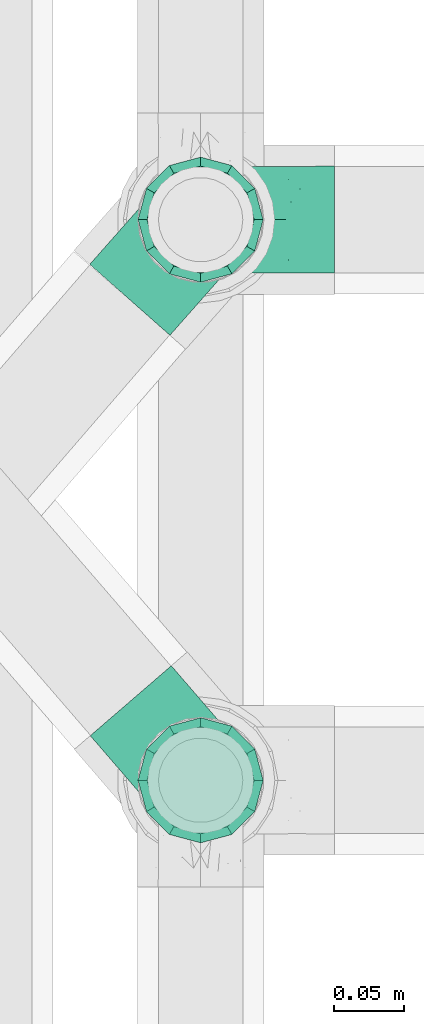
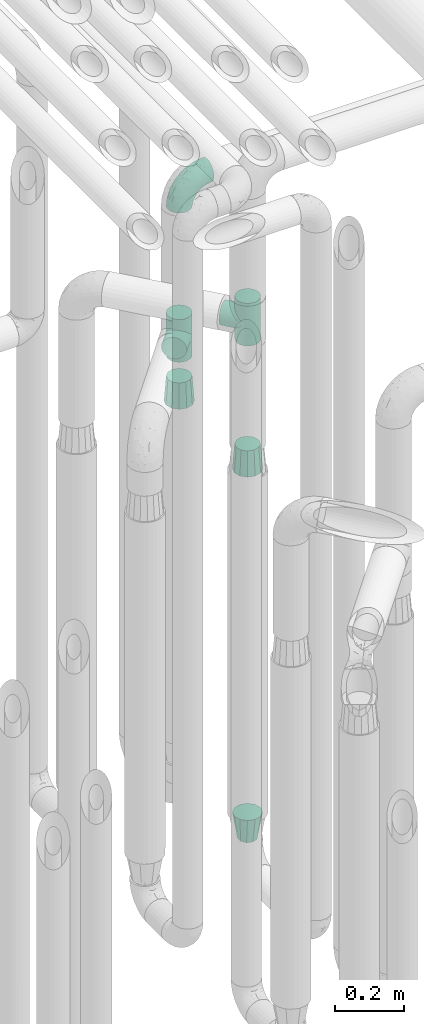
# One storey, part 626 of 827: 6 flow fittings.
"""IFC2X3 building model written with IfcOpenShell, lengths in millimetres."""

from ifc_helpers import new_model, entity, si_unit, converted_unit, derived_unit, direction, frame, origin, place, context, subcontext, project, spatial, faceted_brep, source, transform, mapped, material, type_object, type_shapes, element, save


model = new_model("IFC2X3")

# Units and contexts
model_context = context("Model", 3, precision=0.01, world=origin(), true_north=direction((6.12303176911189e-17, 1.0)))
body_context = subcontext(model_context, "Body", "Model", "MODEL_VIEW")
ifc_project = project(units=[si_unit("LENGTHUNIT", "METRE", prefix="MILLI"), si_unit("AREAUNIT", "SQUARE_METRE"), si_unit("VOLUMEUNIT", "CUBIC_METRE"), converted_unit("PLANEANGLEUNIT", "DEGREE", entity("IfcRatioMeasure", 0.0174532925199433), si_unit("PLANEANGLEUNIT", "RADIAN"), dimensions=[0, 0, 0, 0, 0, 0, 0]), si_unit("MASSUNIT", "GRAM", prefix="KILO"), derived_unit("MASSDENSITYUNIT", [(si_unit("MASSUNIT", "GRAM", prefix="KILO"), 1), (si_unit("LENGTHUNIT", "METRE"), -3)]), derived_unit("MOMENTOFINERTIAUNIT", [(si_unit("LENGTHUNIT", "METRE"), 4)]), si_unit("TIMEUNIT", "SECOND"), si_unit("FREQUENCYUNIT", "HERTZ"), si_unit("THERMODYNAMICTEMPERATUREUNIT", "DEGREE_CELSIUS"), derived_unit("THERMALTRANSMITTANCEUNIT", [(si_unit("MASSUNIT", "GRAM", prefix="KILO"), 1), (si_unit("THERMODYNAMICTEMPERATUREUNIT", "KELVIN"), -1), (si_unit("TIMEUNIT", "SECOND"), -3)]), derived_unit("VOLUMETRICFLOWRATEUNIT", [(si_unit("LENGTHUNIT", "METRE"), 3), (si_unit("TIMEUNIT", "SECOND"), -1)]), derived_unit("MASSFLOWRATEUNIT", [(si_unit("MASSUNIT", "GRAM", prefix="KILO"), 1), (si_unit("TIMEUNIT", "SECOND"), -1)]), derived_unit("ROTATIONALFREQUENCYUNIT", [(si_unit("TIMEUNIT", "SECOND"), -1)]), si_unit("ELECTRICCURRENTUNIT", "AMPERE"), si_unit("ELECTRICVOLTAGEUNIT", "VOLT"), si_unit("POWERUNIT", "WATT"), si_unit("FORCEUNIT", "NEWTON", prefix="KILO"), si_unit("ILLUMINANCEUNIT", "LUX"), si_unit("LUMINOUSFLUXUNIT", "LUMEN"), si_unit("LUMINOUSINTENSITYUNIT", "CANDELA"), derived_unit("USERDEFINED", [(si_unit("MASSUNIT", "GRAM", prefix="KILO"), -1), (si_unit("LENGTHUNIT", "METRE"), -2), (si_unit("TIMEUNIT", "SECOND"), 3), (si_unit("LUMINOUSFLUXUNIT", "LUMEN"), 1)]), derived_unit("LINEARVELOCITYUNIT", [(si_unit("LENGTHUNIT", "METRE"), 1), (si_unit("TIMEUNIT", "SECOND"), -1)]), si_unit("PRESSUREUNIT", "PASCAL"), derived_unit("USERDEFINED", [(si_unit("LENGTHUNIT", "METRE"), -2), (si_unit("MASSUNIT", "GRAM", prefix="KILO"), 1), (si_unit("TIMEUNIT", "SECOND"), -2)]), derived_unit("LINEARFORCEUNIT", [(si_unit("MASSUNIT", "GRAM", prefix="KILO"), 1), (si_unit("LENGTHUNIT", "METRE"), 1), (si_unit("TIMEUNIT", "SECOND"), -2), (si_unit("LENGTHUNIT", "METRE"), -1)]), derived_unit("PLANARFORCEUNIT", [(si_unit("MASSUNIT", "GRAM", prefix="KILO"), 1), (si_unit("LENGTHUNIT", "METRE"), 1), (si_unit("TIMEUNIT", "SECOND"), -2), (si_unit("LENGTHUNIT", "METRE"), -2)])], contexts=[model_context])

# Site, building, storey
site_placement = place(None, origin())
site = spatial("IfcSite", under=ifc_project, at=site_placement, CompositionType="ELEMENT")
building_placement = place(site_placement, origin())
building = spatial("IfcBuilding", under=site, at=building_placement, CompositionType="ELEMENT")
storey_placement = place(building_placement, frame((0.0, 0.0, 28200.0)))
storey = spatial("IfcBuildingStorey", under=building, at=storey_placement, Name="08", CompositionType="ELEMENT", Elevation=28200.0)

# Flow fittings
ifc_material = material()
pipe_fitting_type_1 = type_object("IfcPipeFittingType", Name="ADSK_1", PredefinedType="NOTDEFINED", material=ifc_material)
shared_shape_1 = source(origin(), body_context, "Body", "Brep", [
    faceted_brep([(-95.0, 19.02, -32.95), (-95.0, 9.85, -36.75), (-95.0, 0.0, -38.05), (-95.0, -9.85, -36.75), (-95.0, -19.03, -32.95), (-95.0, -26.91, -26.91), (-95.0, -32.95, -19.03), (-95.0, -36.75, -9.85), (-95.0, -38.05, 0.0), (-95.0, -36.75, 9.85), (-95.0, -32.95, 19.02), (-95.0, -26.91, 26.91), (-95.0, -19.03, 32.95), (-95.0, -9.85, 36.75), (-95.0, 0.0, 38.05), (-95.0, 9.85, 36.75), (-95.0, 19.02, 32.95), (-95.0, 26.91, 26.91), (-95.0, 32.95, 19.02), (-95.0, 36.75, 9.85), (-95.0, 38.05, 0.0), (-95.0, 36.75, -9.85), (-95.0, 32.95, -19.03), (-95.0, 26.91, -26.91), (0.0, 95.0, -38.05), (-9.85, 95.0, -36.75), (-19.02, 95.0, -32.95), (-26.91, 95.0, -26.91), (-32.95, 95.0, -19.03), (-36.75, 95.0, -9.85), (-38.05, 95.0, 0.0), (-36.75, 95.0, 9.85), (-32.95, 95.0, 19.02), (-26.91, 95.0, 26.91), (-19.02, 95.0, 32.95), (-9.85, 95.0, 36.75), (0.0, 95.0, 38.05), (9.85, 95.0, 36.75), (19.03, 95.0, 32.95), (26.91, 95.0, 26.91), (32.95, 95.0, 19.02), (36.75, 95.0, 9.85), (38.05, 95.0, 0.0), (36.75, 95.0, -9.85), (32.95, 95.0, -19.03), (26.91, 95.0, -26.91), (19.03, 95.0, -32.95), (9.85, 95.0, -36.75), (-7.99, -4.96, 6.3), (-0.92, 0.92, 0.0), (4.62, 8.1, 8.01), (-76.19, -35.57, 0.0), (-64.32, -32.32, 12.43), (20.51, 62.45, 28.68), (-60.56, -33.52, 0.0), (-70.4, -13.47, 34.42), (-39.61, -5.88, 32.32), (-49.6, 2.07, 37.1), (-70.34, -28.81, 21.71), (14.64, 40.81, 26.5), (5.88, 39.61, 32.32), (3.59, 20.77, 25.31), (-40.45, 68.06, 16.75), (-62.45, -20.51, 28.68), (-44.52, -26.87, 0.0), (-28.47, -20.22, 0.0), (-26.43, -17.83, 8.75), (-76.1, 39.63, 10.76), (-72.74, 37.58, 18.19), (-60.35, 46.18, 14.61), (-13.4, 13.4, 32.12), (-20.77, -3.59, 25.31), (-14.66, 81.47, 35.56), (-6.22, 71.26, 37.92), (-57.5, 42.48, 22.79), (-15.0, 34.74, 37.7), (-27.1, 12.08, 36.05), (-9.2, 28.81, 35.63), (-79.98, 23.7, 30.95), (-73.68, -4.3, 37.48), (-30.74, 21.67, 37.97), (-62.36, 47.59, 6.79), (-72.71, 32.83, 24.69), (-67.42, 7.02, 37.95), (-32.13, 75.27, 24.51), (-43.46, 51.47, 26.26), (-24.98, 73.15, 31.29), (20.59, 41.28, 19.85), (7.79, 16.09, 15.86), (-73.21, 42.39, 0.0), (-54.73, 54.73, 0.0), (-73.44, 15.79, 35.79), (-5.94, 4.32, 20.43), (28.81, 70.34, 21.71), (32.32, 64.32, 12.43), (-53.59, 26.2, 35.09), (-52.02, 19.31, 37.21), (21.38, 33.53, 10.34), (26.87, 44.52, 0.0), (-48.28, 12.14, 38.05), (4.3, 73.68, 37.48), (-44.08, -25.52, 12.79), (-41.28, -20.59, 19.85), (35.57, 76.19, 0.0), (-47.26, 54.3, 20.18), (-47.4, 61.99, 8.58), (-42.39, 73.21, 0.0), (-39.67, 78.86, 7.21), (-45.69, 36.84, 33.11), (-32.83, 50.13, 33.35), (13.47, 70.4, 34.42), (-18.25, 63.73, 36.07), (-40.63, -13.75, 27.22), (-16.63, 46.37, 37.95), (-53.47, 38.79, 28.59), (-26.07, 48.54, 36.15), (-34.51, 34.51, 36.86), (-2.07, 49.6, 37.1), (-22.79, -10.49, 19.23), (-61.73, 28.67, 31.87), (9.65, 14.7, 0.0), (20.22, 28.47, 0.0), (33.52, 60.56, 0.0), (-11.42, -5.44, 13.25), (-14.7, -9.65, 0.0), (-81.47, 14.66, -35.56), (-62.45, -20.51, -28.68), (-71.26, 6.22, -37.92), (-75.27, 32.13, -24.51), (-73.15, 24.98, -31.29), (13.47, 70.4, -34.42), (5.88, 39.61, -32.32), (-2.07, 49.6, -37.1), (-78.86, 39.67, -7.21), (-70.4, -13.47, -34.42), (-39.61, -5.88, -32.32), (-61.99, 47.4, -8.58), (32.32, 64.32, -12.43), (28.81, 70.34, -21.71), (-63.73, 18.25, -36.07), (-50.13, 32.83, -33.35), (4.3, 73.68, -37.48), (-7.02, 67.42, -37.95), (-39.63, 76.1, -10.76), (-46.18, 60.35, -14.61), (-47.59, 62.36, -6.79), (-64.32, -32.32, -12.43), (-26.2, 53.59, -35.09), (-15.79, 73.44, -35.79), (-19.31, 52.02, -37.21), (-37.58, 72.74, -18.19), (-70.34, -28.81, -21.71), (-42.48, 57.5, -22.79), (-38.79, 53.47, -28.59), (-51.47, 43.46, -26.26), (-32.83, 72.71, -24.69), (-46.37, 16.63, -37.95), (-73.68, -4.3, -37.48), (-41.28, -20.59, -19.85), (-44.08, -25.52, -12.79), (13.75, 40.63, -27.22), (20.51, 62.45, -28.68), (-68.06, 40.45, -16.75), (-54.3, 47.26, -20.18), (-12.14, 48.28, -38.05), (-21.67, 30.74, -37.97), (-36.84, 45.69, -33.11), (-11.42, -5.44, -13.25), (7.79, 16.09, -15.86), (4.62, 8.1, -8.01), (-23.7, 79.98, -30.95), (-26.43, -17.83, -8.75), (-7.99, -4.96, -6.3), (-40.81, -14.64, -26.5), (-20.77, -3.59, -25.31), (-34.74, 15.0, -37.7), (-12.08, 27.1, -36.05), (-28.81, 9.2, -35.63), (-22.79, -10.49, -19.23), (21.38, 33.53, -10.34), (20.59, 41.28, -19.85), (-48.54, 26.07, -36.15), (-49.6, 2.07, -37.1), (-13.4, 13.4, -32.12), (3.59, 20.77, -25.31), (-28.67, 61.73, -31.87), (-34.51, 34.51, -36.86), (-5.94, 4.32, -20.43)], [[[0, 1, 2, 3, 4, 5, 6, 7, 8, 9, 10, 11, 12, 13, 14, 15, 16, 17, 18, 19, 20, 21, 22, 23]], [[24, 25, 26, 27, 28, 29, 30, 31, 32, 33, 34, 35, 36, 37, 38, 39, 40, 41, 42, 43, 44, 45, 46, 47]], [[48, 49, 50]], [[51, 52, 9]], [[53, 39, 38]], [[9, 52, 10]], [[54, 52, 51]], [[55, 56, 57]], [[11, 10, 58]], [[59, 60, 61]], [[32, 31, 62]], [[63, 12, 11]], [[63, 55, 12]], [[64, 65, 66]], [[67, 68, 69]], [[70, 56, 71]], [[35, 72, 73]], [[69, 68, 74]], [[75, 76, 77]], [[16, 78, 17]], [[13, 79, 14]], [[76, 75, 80]], [[67, 69, 81]], [[18, 17, 82]], [[14, 79, 83]], [[20, 19, 67]], [[84, 85, 86]], [[87, 61, 88]], [[89, 81, 90]], [[18, 82, 68]], [[15, 91, 16]], [[14, 83, 15]], [[71, 92, 61]], [[17, 78, 82]], [[93, 87, 94]], [[95, 91, 96]], [[97, 98, 94]], [[86, 72, 34]], [[96, 99, 80]], [[37, 36, 100]], [[40, 39, 93]], [[40, 94, 41]], [[64, 66, 101]], [[93, 94, 40]], [[58, 102, 63]], [[94, 103, 41]], [[94, 87, 97]], [[104, 69, 74]], [[34, 33, 86]], [[105, 69, 104]], [[52, 58, 10]], [[106, 107, 30]], [[108, 109, 85]], [[105, 106, 90]], [[53, 110, 60]], [[86, 111, 72]], [[86, 109, 111]], [[33, 84, 86]], [[12, 55, 13]], [[112, 56, 63]], [[110, 38, 37]], [[34, 72, 35]], [[36, 35, 73]], [[111, 113, 73]], [[105, 107, 106]], [[110, 53, 38]], [[74, 114, 85]], [[91, 15, 83]], [[105, 90, 81]], [[107, 62, 31]], [[33, 32, 84]], [[115, 109, 116]], [[111, 115, 113]], [[100, 73, 117]], [[56, 55, 63]], [[79, 55, 57]], [[102, 118, 112]], [[56, 70, 76]], [[100, 110, 37]], [[117, 77, 60]], [[117, 60, 110]], [[60, 70, 61]], [[58, 52, 101]], [[63, 11, 58]], [[39, 53, 93]], [[87, 93, 53]], [[96, 91, 83]], [[78, 91, 119]], [[32, 62, 84]], [[84, 62, 104]], [[86, 85, 109]], [[85, 114, 108]], [[80, 113, 116]], [[117, 73, 113]], [[80, 116, 96]], [[80, 57, 76]], [[71, 112, 118]], [[61, 87, 59]], [[62, 107, 105]], [[97, 120, 121]], [[70, 71, 61]], [[71, 118, 92]], [[73, 100, 36]], [[110, 100, 117]], [[55, 79, 13]], [[83, 79, 57]], [[96, 83, 99]], [[116, 108, 95]], [[50, 97, 88]], [[97, 87, 88]], [[50, 49, 120]], [[122, 94, 98]], [[89, 20, 67]], [[105, 81, 69]], [[89, 67, 81]], [[68, 19, 18]], [[68, 67, 19]], [[74, 68, 82]], [[114, 82, 119]], [[74, 85, 104]], [[82, 114, 74]], [[114, 119, 108]], [[95, 108, 119]], [[116, 109, 108]], [[123, 48, 50]], [[97, 50, 120]], [[123, 50, 88]], [[91, 95, 119]], [[116, 95, 96]], [[84, 104, 85]], [[104, 62, 105]], [[83, 57, 99]], [[57, 80, 99]], [[66, 48, 123]], [[66, 124, 48]], [[118, 66, 123]], [[124, 66, 65]], [[66, 118, 101]], [[54, 64, 52]], [[124, 49, 48]], [[30, 107, 31]], [[91, 78, 16]], [[82, 78, 119]], [[56, 76, 57]], [[77, 76, 70]], [[60, 77, 70]], [[77, 117, 75]], [[117, 113, 75]], [[113, 80, 75]], [[9, 8, 51]], [[103, 94, 122]], [[103, 42, 41]], [[73, 72, 111]], [[113, 115, 116]], [[111, 109, 115]], [[102, 112, 63]], [[71, 56, 112]], [[118, 102, 101]], [[92, 123, 88]], [[123, 92, 118]], [[61, 92, 88]], [[87, 53, 59]], [[60, 59, 53]], [[97, 121, 98]], [[58, 101, 102]], [[64, 101, 52]], [[125, 1, 0]], [[126, 5, 4]], [[2, 1, 127]], [[1, 125, 127]], [[128, 129, 23]], [[130, 131, 132]], [[89, 133, 20]], [[126, 134, 135]], [[136, 89, 90]], [[137, 138, 44]], [[139, 129, 140]], [[24, 141, 142]], [[143, 144, 145]], [[125, 129, 139]], [[6, 146, 7]], [[147, 148, 149]], [[146, 51, 7]], [[143, 150, 144]], [[146, 6, 151]], [[152, 153, 154]], [[126, 4, 134]], [[0, 23, 129]], [[28, 155, 150]], [[43, 42, 103]], [[54, 146, 64]], [[139, 156, 127]], [[157, 3, 2]], [[151, 158, 159]], [[160, 131, 161]], [[22, 21, 162]], [[136, 144, 163]], [[149, 164, 165]], [[24, 142, 25]], [[166, 140, 154]], [[154, 129, 128]], [[143, 30, 29]], [[167, 168, 169]], [[155, 28, 27]], [[26, 170, 27]], [[171, 167, 172]], [[26, 25, 148]], [[27, 170, 155]], [[173, 135, 174]], [[144, 150, 152]], [[175, 176, 177]], [[24, 47, 141]], [[45, 161, 46]], [[148, 25, 142]], [[176, 175, 165]], [[64, 159, 171]], [[138, 45, 44]], [[130, 46, 161]], [[137, 44, 43]], [[178, 159, 158]], [[137, 103, 122]], [[163, 144, 152]], [[136, 133, 89]], [[103, 137, 43]], [[6, 5, 151]], [[178, 158, 173]], [[134, 4, 3]], [[178, 173, 174]], [[137, 98, 179]], [[145, 90, 106]], [[138, 180, 161]], [[46, 130, 47]], [[136, 90, 145]], [[133, 162, 21]], [[23, 22, 128]], [[139, 140, 181]], [[139, 181, 156]], [[157, 127, 182]], [[157, 134, 3]], [[182, 177, 135]], [[182, 135, 134]], [[135, 183, 174]], [[131, 130, 161]], [[141, 130, 132]], [[160, 180, 184]], [[131, 183, 176]], [[5, 126, 151]], [[158, 151, 126]], [[180, 138, 137]], [[161, 45, 138]], [[149, 148, 142]], [[170, 148, 185]], [[22, 162, 128]], [[128, 162, 163]], [[129, 154, 140]], [[154, 153, 166]], [[165, 156, 186]], [[182, 127, 156]], [[165, 186, 149]], [[165, 132, 176]], [[131, 184, 183]], [[187, 167, 178]], [[184, 168, 187]], [[167, 169, 172]], [[184, 180, 168]], [[174, 183, 184]], [[127, 157, 2]], [[134, 157, 182]], [[130, 141, 47]], [[142, 141, 132]], [[149, 142, 164]], [[186, 166, 147]], [[180, 179, 168]], [[169, 179, 120]], [[137, 179, 180]], [[179, 121, 120]], [[106, 30, 143]], [[136, 145, 144]], [[106, 143, 145]], [[150, 29, 28]], [[150, 143, 29]], [[152, 150, 155]], [[153, 155, 185]], [[152, 154, 163]], [[155, 153, 152]], [[153, 185, 166]], [[147, 166, 185]], [[186, 140, 166]], [[169, 120, 49]], [[169, 49, 172]], [[179, 169, 168]], [[148, 147, 185]], [[186, 147, 149]], [[128, 163, 154]], [[163, 162, 136]], [[142, 132, 164]], [[132, 165, 164]], [[171, 124, 65]], [[124, 171, 172]], [[64, 146, 159]], [[171, 159, 178]], [[171, 65, 64]], [[172, 49, 124]], [[162, 133, 136]], [[20, 133, 21]], [[148, 170, 26]], [[155, 170, 185]], [[131, 176, 132]], [[177, 176, 183]], [[135, 177, 183]], [[177, 182, 175]], [[182, 156, 175]], [[156, 165, 175]], [[51, 146, 54]], [[51, 8, 7]], [[129, 125, 0]], [[127, 125, 139]], [[140, 186, 181]], [[156, 181, 186]], [[158, 126, 173]], [[135, 173, 126]], [[187, 178, 174]], [[171, 178, 167]], [[184, 187, 174]], [[167, 187, 168]], [[180, 160, 161]], [[184, 131, 160]], [[98, 137, 122]], [[98, 121, 179]], [[151, 159, 146]]]),
])
type_shapes(pipe_fitting_type_1, [shared_shape_1])
flow_fitting_1_placement = place(storey_placement, frame((36975.03, 12979.64, 2600.0), z_axis=(0.0, 1.0, 0.0), x_axis=(0.0, 0.0, 1.0)))
element("IfcFlowFitting", 1, at=flow_fitting_1_placement, inside=storey, type_object=pipe_fitting_type_1, material=ifc_material, Name="ADSK_1", ObjectType="ADSK_1", context=body_context, shape_type="MappedRepresentation", body=[
    mapped(shared_shape_1, transform((0.0, 0.0, 0.0), scale=1.0)),
])
pipe_fitting_type_2 = type_object("IfcPipeFittingType", Name="ADSK_1", PredefinedType="NOTDEFINED", material=ifc_material)
shared_shape_2 = source(origin(), body_context, "Body", "Brep", [
    faceted_brep([(-76.0, 9.85, -36.75), (-76.0, 0.0, -38.05), (-76.0, -9.85, -36.75), (-76.0, -19.03, -32.95), (-76.0, -22.97, -29.93), (-76.0, -26.91, -26.91), (-76.0, -29.93, -22.97), (-76.0, -32.95, -19.03), (-76.0, -34.85, -14.44), (-76.0, -36.75, -9.85), (-76.0, -38.05, 0.0), (-76.0, -36.75, 9.85), (-76.0, -34.85, 14.44), (-76.0, -32.95, 19.02), (-76.0, -29.93, 22.97), (-76.0, -26.91, 26.91), (-76.0, -22.97, 29.93), (-76.0, -19.03, 32.95), (-76.0, -9.85, 36.75), (-76.0, 0.0, 38.05), (-76.0, 9.85, 36.75), (-76.0, 19.02, 32.95), (-76.0, 26.91, 26.91), (-76.0, 32.95, 19.02), (-76.0, 36.75, 9.85), (-76.0, 38.05, 0.0), (-76.0, 36.75, -9.85), (-76.0, 32.95, -19.03), (-76.0, 26.91, -26.91), (-76.0, 19.02, -32.95), (76.0, 26.91, -26.91), (76.0, 32.95, -19.03), (76.0, 36.75, -9.85), (76.0, 38.05, 0.0), (76.0, 36.75, 9.85), (76.0, 32.95, 19.02), (76.0, 26.91, 26.91), (76.0, 19.02, 32.95), (76.0, 9.85, 36.75), (76.0, 0.0, 38.05), (76.0, -9.85, 36.75), (76.0, -19.03, 32.95), (76.0, -22.97, 29.93), (76.0, -26.91, 26.91), (76.0, -29.93, 22.97), (76.0, -32.95, 19.02), (76.0, -34.85, 14.44), (76.0, -36.75, 9.85), (76.0, -38.05, 0.0), (76.0, -36.75, -9.85), (76.0, -34.85, -14.44), (76.0, -32.95, -19.03), (76.0, -29.93, -22.97), (76.0, -26.91, -26.91), (76.0, -22.97, -29.93), (76.0, -19.03, -32.95), (76.0, -9.85, -36.75), (76.0, 0.0, -38.05), (76.0, 9.85, -36.75), (76.0, 19.02, -32.95), (36.99, -36.99, 8.94), (38.05, -38.05, 0.0), (-36.99, -36.99, 8.94), (-38.05, -38.05, 0.0), (35.51, -35.51, 12.97), (34.04, -34.04, 17.0), (18.81, -18.81, 33.08), (29.74, -29.74, 23.73), (24.56, -24.56, 29.06), (-35.51, -35.51, 12.97), (-34.04, -34.04, 17.0), (-18.81, -18.81, 33.08), (-29.74, -29.74, 23.73), (-24.56, -24.56, 29.06), (-12.7, -12.7, 35.87), (6.4, -6.4, 37.51), (12.7, -12.7, 35.87), (0.0, 0.0, 38.05), (-6.4, -6.4, 37.51), (6.4, -6.4, -37.51), (0.0, 0.0, -38.05), (12.7, -12.7, -35.87), (-24.56, -24.56, -29.06), (-6.4, -6.4, -37.51), (-35.51, -35.51, -12.97), (-36.99, -36.99, -8.94), (-29.74, -29.74, -23.73), (-12.7, -12.7, -35.87), (18.81, -18.81, -33.08), (24.56, -24.56, -29.06), (-34.04, -34.04, -17.0), (29.74, -29.74, -23.73), (36.99, -36.99, -8.94), (35.51, -35.51, -12.97), (34.04, -34.04, -17.0), (-18.81, -18.81, -33.08), (9.85, -76.0, -36.75), (19.03, -76.0, -32.95), (26.91, -76.0, -26.91), (32.95, -76.0, -19.03), (36.75, -76.0, -9.85), (38.05, -76.0, 0.0), (36.75, -76.0, 9.85), (32.95, -76.0, 19.02), (26.91, -76.0, 26.91), (19.03, -76.0, 32.95), (9.85, -76.0, 36.75), (0.0, -76.0, 38.05), (-9.85, -76.0, 36.75), (-19.02, -76.0, 32.95), (-26.91, -76.0, 26.91), (-32.95, -76.0, 19.02), (-36.75, -76.0, 9.85), (-38.05, -76.0, 0.0), (-36.75, -76.0, -9.85), (-32.95, -76.0, -19.03), (-26.91, -76.0, -26.91), (-19.02, -76.0, -32.95), (-9.85, -76.0, -36.75), (0.0, -76.0, -38.05)], [[[0, 1, 2, 3, 4, 5, 6, 7, 8, 9, 10, 11, 12, 13, 14, 15, 16, 17, 18, 19, 20, 21, 22, 23, 24, 25, 26, 27, 28, 29]], [[30, 31, 32, 33, 34, 35, 36, 37, 38, 39, 40, 41, 42, 43, 44, 45, 46, 47, 48, 49, 50, 51, 52, 53, 54, 55, 56, 57, 58, 59]], [[48, 47, 60]], [[60, 61, 48]], [[62, 10, 63]], [[47, 46, 64]], [[46, 45, 65]], [[41, 66, 42]], [[43, 67, 45, 44]], [[67, 43, 68]], [[45, 67, 65]], [[68, 43, 42]], [[11, 69, 12]], [[70, 12, 69]], [[10, 62, 11]], [[11, 62, 69]], [[71, 17, 16]], [[72, 73, 15]], [[72, 15, 14, 13]], [[15, 73, 16]], [[71, 74, 17]], [[72, 13, 70]], [[46, 65, 64]], [[42, 66, 68]], [[40, 39, 75]], [[47, 64, 60]], [[66, 41, 76]], [[75, 76, 40]], [[75, 39, 77]], [[78, 77, 19]], [[76, 41, 40]], [[23, 22, 36, 35]], [[24, 23, 35, 34]], [[21, 20, 38, 37]], [[22, 21, 37, 36]], [[38, 20, 19, 77, 39]], [[25, 24, 34, 33]], [[70, 13, 12]], [[78, 18, 74]], [[18, 78, 19]], [[18, 17, 74]], [[71, 16, 73]], [[28, 27, 31, 30]], [[26, 32, 31, 27]], [[25, 33, 32, 26]], [[29, 28, 30, 59]], [[57, 56, 79]], [[58, 57, 80, 1, 0]], [[79, 56, 81]], [[82, 5, 4]], [[59, 58, 0, 29]], [[56, 55, 81]], [[57, 79, 80]], [[80, 83, 1]], [[9, 84, 85]], [[86, 7, 6, 5]], [[83, 87, 2]], [[1, 83, 2]], [[87, 3, 2]], [[88, 54, 89]], [[54, 53, 89]], [[8, 90, 84]], [[88, 55, 54]], [[91, 89, 53]], [[52, 51, 91, 53]], [[55, 88, 81]], [[49, 92, 93]], [[92, 49, 48]], [[94, 50, 93]], [[61, 92, 48]], [[85, 63, 10]], [[51, 94, 91]], [[82, 4, 95]], [[49, 93, 50]], [[4, 3, 95]], [[5, 82, 86]], [[94, 51, 50]], [[95, 3, 87]], [[9, 8, 84]], [[90, 8, 7]], [[9, 85, 10]], [[90, 7, 86]], [[96, 97, 98, 99, 100, 101, 102, 103, 104, 105, 106, 107, 108, 109, 110, 111, 112, 113, 114, 115, 116, 117, 118, 119]], [[62, 63, 113]], [[112, 62, 113]], [[110, 109, 73]], [[72, 111, 110]], [[70, 112, 111]], [[74, 109, 108]], [[112, 70, 69, 62]], [[73, 72, 110]], [[70, 111, 72]], [[74, 71, 109]], [[107, 77, 78]], [[74, 108, 78]], [[73, 109, 71]], [[78, 108, 107]], [[75, 107, 106]], [[105, 76, 106]], [[103, 102, 65]], [[67, 104, 103]], [[68, 105, 104]], [[60, 102, 101]], [[68, 66, 105]], [[76, 75, 106]], [[66, 76, 105]], [[61, 60, 101]], [[65, 67, 103]], [[102, 60, 64, 65]], [[68, 104, 67]], [[107, 75, 77]], [[61, 101, 92]], [[100, 92, 101]], [[98, 97, 89]], [[94, 100, 99]], [[98, 91, 99]], [[81, 97, 96]], [[100, 94, 93, 92]], [[89, 91, 98]], [[94, 99, 91]], [[81, 88, 97]], [[119, 80, 79]], [[81, 96, 79]], [[89, 97, 88]], [[79, 96, 119]], [[83, 119, 118]], [[117, 87, 118]], [[115, 114, 90]], [[86, 116, 115]], [[82, 117, 116]], [[85, 114, 113]], [[82, 95, 117]], [[87, 83, 118]], [[95, 87, 117]], [[63, 85, 113]], [[90, 86, 115]], [[114, 85, 84, 90]], [[82, 116, 86]], [[119, 83, 80]]]),
])
type_shapes(pipe_fitting_type_2, [shared_shape_2])
for number, where, z_axis, x_axis, name in (
    (2, (36975.03, 12580.2, 2350.0), (0.757098240256198, 0.653301044389926, 0.0), (0.0, 0.0, 1.0), "ADSK_1"),
    (3, (36975.03, 12979.64, 2050.0), (-0.749374472575658, 0.662146433843719, 0.0), (0.0, 0.0, 1.0), "ADSK_1"),
):
    element("IfcFlowFitting", number, at=place(storey_placement, frame(where, z_axis=z_axis, x_axis=x_axis)), inside=storey, type_object=pipe_fitting_type_2, material=ifc_material, Name=name, ObjectType="ADSK_1", context=body_context, shape_type="MappedRepresentation", body=[
        mapped(shared_shape_2, transform((0.0, 0.0, 0.0), scale=1.0)),
    ])
pipe_fitting_type_3 = type_object("IfcPipeFittingType", Name="ADSK_1", PredefinedType="NOTDEFINED", material=ifc_material)
shared_shape_3 = source(origin(), body_context, "Body", "Brep", [
    faceted_brep([(89.0, -44.45, 0.0), (89.0, -41.96, -9.31), (89.0, -38.49, -22.22), (89.0, -30.36, -30.36), (89.0, -22.23, -38.49), (89.0, -11.11, -41.47), (89.0, 0.0, -44.45), (89.0, 11.11, -41.47), (89.0, 22.22, -38.49), (89.0, 30.36, -30.36), (89.0, 38.49, -22.22), (89.0, 41.96, -9.31), (89.0, 44.45, 0.0), (89.0, 41.96, 9.31), (89.0, 38.49, 22.23), (89.0, 30.36, 30.36), (89.0, 22.22, 38.49), (89.0, 11.11, 41.47), (89.0, 0.0, 44.45), (89.0, -11.11, 41.47), (89.0, -22.23, 38.49), (89.0, -30.36, 30.36), (89.0, -38.49, 22.23), (89.0, -41.96, 9.31), (0.0, 38.05, 0.0), (0.0, 35.5, -9.51), (0.0, 32.95, -19.02), (0.0, 25.99, -25.99), (0.0, 19.02, -32.95), (0.0, 9.51, -35.5), (0.0, 0.0, -38.05), (0.0, -9.51, -35.5), (0.0, -19.03, -32.95), (0.0, -25.99, -25.99), (0.0, -32.95, -19.02), (0.0, -35.5, -9.51), (0.0, -38.05, 0.0), (0.0, -35.5, 9.51), (0.0, -32.95, 19.03), (0.0, -25.99, 25.99), (0.0, -19.03, 32.95), (0.0, -9.51, 35.5), (0.0, 0.0, 38.05), (0.0, 9.51, 35.5), (0.0, 19.03, 32.95), (0.0, 25.99, 25.99), (0.0, 32.95, 19.03), (0.0, 35.5, 9.51)], [[[0, 1, 2, 3, 4, 5, 6, 7, 8, 9, 10, 11, 12, 13, 14, 15, 16, 17, 18, 19, 20, 21, 22, 23]], [[24, 25, 26, 27, 28, 29, 30, 31, 32, 33, 34, 35, 36, 37, 38, 39, 40, 41, 42, 43, 44, 45, 46, 47]], [[2, 1, 0, 36, 35, 34]], [[28, 8, 7, 6, 30, 29]], [[32, 4, 3, 2, 34, 33]], [[5, 4, 32, 31, 30, 6]], [[10, 26, 25, 24, 12, 11]], [[9, 8, 28, 27, 26, 10]], [[14, 13, 12, 24, 47, 46]], [[40, 20, 19, 18, 42, 41]], [[44, 16, 15, 14, 46, 45]], [[17, 16, 44, 43, 42, 18]], [[22, 38, 37, 36, 0, 23]], [[21, 20, 40, 39, 38, 22]]]),
])
type_shapes(pipe_fitting_type_3, [shared_shape_3])
flow_fitting_2_placement = place(storey_placement, frame((36975.03, 12581.17, 1900.0), z_axis=(0.0, 1.0, 0.0), x_axis=(0.0, 0.0, -1.0)))
element("IfcFlowFitting", 4, at=flow_fitting_2_placement, inside=storey, type_object=pipe_fitting_type_3, material=ifc_material, Name="ADSK_1", ObjectType="ADSK_1", context=body_context, shape_type="MappedRepresentation", body=[
    mapped(shared_shape_3, transform((0.0, 0.0, 0.0), scale=1.0)),
])
pipe_fitting_type_4 = type_object("IfcPipeFittingType", Name="ADSK_1", PredefinedType="NOTDEFINED", material=ifc_material)
shared_shape_4 = source(origin(), body_context, "Body", "Brep", [
    faceted_brep([(89.0, -44.45, 0.0), (89.0, -42.1, -8.76), (89.0, -38.49, -22.22), (89.0, -30.36, -30.36), (89.0, -22.23, -38.49), (89.0, -11.11, -41.47), (89.0, 0.0, -44.45), (89.0, 11.11, -41.47), (89.0, 22.22, -38.49), (89.0, 30.36, -30.36), (89.0, 38.49, -22.22), (89.0, 42.1, -8.76), (89.0, 44.45, 0.0), (89.0, 42.1, 8.76), (89.0, 38.49, 22.23), (89.0, 30.36, 30.36), (89.0, 22.22, 38.49), (89.0, 11.11, 41.47), (89.0, 0.0, 44.45), (89.0, -11.11, 41.47), (89.0, -22.23, 38.49), (89.0, -30.36, 30.36), (89.0, -38.49, 22.23), (89.0, -42.1, 8.76), (0.0, 30.15, 0.0), (0.0, 27.27, -8.86), (0.0, 24.39, -17.72), (0.0, 16.85, -23.2), (0.0, 9.32, -28.67), (0.0, 0.0, -28.67), (0.0, -9.32, -28.67), (0.0, -16.85, -23.2), (0.0, -24.39, -17.72), (0.0, -27.27, -8.86), (0.0, -30.15, 0.0), (0.0, -27.27, 8.86), (0.0, -24.39, 17.72), (0.0, -16.85, 23.2), (0.0, -9.32, 28.67), (0.0, 0.0, 28.67), (0.0, 9.32, 28.67), (0.0, 16.85, 23.2), (0.0, 24.39, 17.72), (0.0, 27.27, 8.86)], [[[0, 1, 2, 3, 4, 5, 6, 7, 8, 9, 10, 11, 12, 13, 14, 15, 16, 17, 18, 19, 20, 21, 22, 23]], [[24, 25, 26, 27, 28, 29, 30, 31, 32, 33, 34, 35, 36, 37, 38, 39, 40, 41, 42, 43]], [[2, 33, 32]], [[28, 7, 29]], [[29, 5, 30]], [[24, 12, 11]], [[3, 32, 31]], [[34, 1, 0]], [[1, 34, 33]], [[8, 28, 27]], [[2, 1, 33]], [[31, 4, 3]], [[2, 32, 3]], [[11, 25, 24]], [[26, 10, 9]], [[10, 25, 11]], [[28, 8, 7]], [[27, 26, 9]], [[26, 25, 10]], [[31, 30, 4]], [[8, 27, 9]], [[29, 7, 6]], [[5, 29, 6]], [[5, 4, 30]], [[14, 43, 42]], [[38, 19, 39]], [[39, 17, 40]], [[34, 0, 23]], [[15, 42, 41]], [[24, 13, 12]], [[13, 24, 43]], [[20, 38, 37]], [[14, 13, 43]], [[41, 16, 15]], [[14, 42, 15]], [[23, 35, 34]], [[36, 22, 21]], [[22, 35, 23]], [[38, 20, 19]], [[37, 36, 21]], [[36, 35, 22]], [[41, 40, 16]], [[20, 37, 21]], [[39, 19, 18]], [[17, 39, 18]], [[17, 16, 40]]]),
])
type_shapes(pipe_fitting_type_4, [shared_shape_4])
flow_fitting_3_placement = place(storey_placement, frame((36975.03, 12581.17, 500.0), z_axis=(1.0, 0.0, 0.0), x_axis=(0.0, 0.0, 1.0)))
element("IfcFlowFitting", 5, at=flow_fitting_3_placement, inside=storey, type_object=pipe_fitting_type_4, material=ifc_material, Name="ADSK_1", ObjectType="ADSK_1", context=body_context, shape_type="MappedRepresentation", body=[
    mapped(shared_shape_4, transform((0.0, 0.0, 0.0), scale=1.0)),
])
pipe_fitting_type_5 = type_object("IfcPipeFittingType", Name="ADSK_1", PredefinedType="NOTDEFINED", material=ifc_material)
shared_shape_5 = source(origin(), body_context, "Body", "Brep", [
    faceted_brep([(89.0, 38.05, 0.0), (89.0, 35.5, 9.51), (89.0, 32.95, 19.03), (89.0, 25.99, 25.99), (89.0, 19.02, 32.95), (89.0, 9.51, 35.5), (89.0, 0.0, 38.05), (89.0, -9.51, 35.5), (89.0, -19.03, 32.95), (89.0, -25.99, 25.99), (89.0, -32.95, 19.03), (89.0, -35.5, 9.51), (89.0, -38.05, 0.0), (89.0, -35.5, -9.51), (89.0, -32.95, -19.02), (89.0, -25.99, -25.99), (89.0, -19.03, -32.95), (89.0, -9.51, -35.5), (89.0, 0.0, -38.05), (89.0, 9.51, -35.5), (89.0, 19.02, -32.95), (89.0, 25.99, -25.99), (89.0, 32.95, -19.03), (89.0, 35.5, -9.51), (0.0, -38.49, 22.22), (0.0, -30.36, 30.36), (0.0, -22.22, 38.49), (0.0, -11.11, 41.47), (0.0, 0.0, 44.45), (0.0, 11.11, 41.47), (0.0, 22.23, 38.49), (0.0, 30.36, 30.36), (0.0, 38.49, 22.22), (0.0, 41.96, 9.31), (0.0, 44.45, 0.0), (0.0, 41.47, -11.11), (0.0, 38.49, -22.23), (0.0, 30.36, -30.36), (0.0, 22.23, -38.49), (0.0, 11.11, -41.47), (0.0, 0.0, -44.45), (0.0, -11.11, -41.47), (0.0, -22.23, -38.49), (0.0, -30.36, -30.36), (0.0, -38.49, -22.23), (0.0, -41.96, -9.31), (0.0, -44.45, 0.0), (0.0, -41.47, 11.11)], [[[0, 1, 2, 3, 4, 5, 6, 7, 8, 9, 10, 11, 12, 13, 14, 15, 16, 17, 18, 19, 20, 21, 22, 23]], [[24, 25, 26, 27, 28, 29, 30, 31, 32, 33, 34, 35, 36, 37, 38, 39, 40, 41, 42, 43, 44, 45, 46, 47]], [[23, 22, 36, 35, 34, 0]], [[39, 38, 20, 19, 18, 40]], [[38, 37, 36, 22, 21, 20]], [[43, 42, 16, 15, 14, 44]], [[41, 40, 18, 17, 16, 42]], [[12, 46, 45, 44, 14, 13]], [[11, 10, 24, 47, 46, 12]], [[27, 26, 8, 7, 6, 28]], [[26, 25, 24, 10, 9, 8]], [[31, 30, 4, 3, 2, 32]], [[29, 28, 6, 5, 4, 30]], [[0, 34, 33, 32, 2, 1]]]),
])
type_shapes(pipe_fitting_type_5, [shared_shape_5])
flow_fitting_4_placement = place(storey_placement, frame((36975.03, 12979.64, 1811.0), z_axis=(1.0, 0.0, 0.0), x_axis=(0.0, 0.0, 1.0)))
element("IfcFlowFitting", 6, at=flow_fitting_4_placement, inside=storey, type_object=pipe_fitting_type_5, material=ifc_material, Name="ADSK_1", ObjectType="ADSK_1", context=body_context, shape_type="MappedRepresentation", body=[
    mapped(shared_shape_5, transform((0.0, 0.0, 0.0), scale=1.0)),
])

save(model, "model.ifc")
